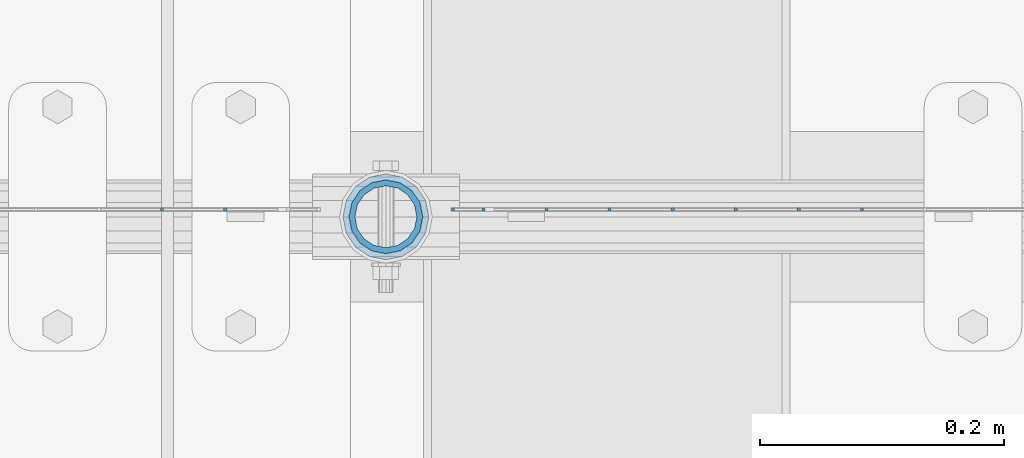
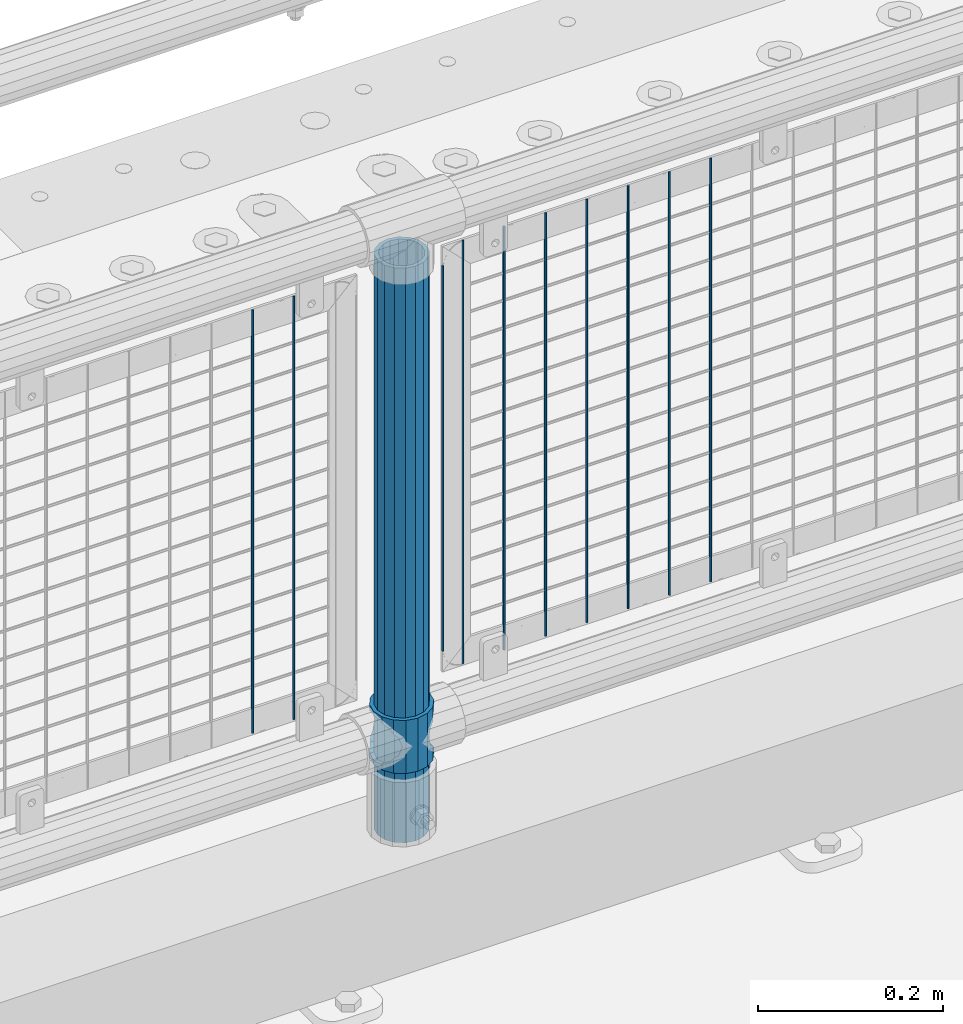
# One storey, part 90 of 240: 12 columns.
"""IFC2X3 building model written with IfcOpenShell, lengths in millimetres."""

from ifc_helpers import new_model, si_unit, frame, origin_with_axes, place, context, subcontext, project, spatial, faceted_brep, material, type_object, element, save


model = new_model("IFC2X3")

# Units and contexts
model_context = context("Model", 3, precision=1e-05, world=origin_with_axes())
body_context = subcontext(model_context, "Body", "Model", "MODEL_VIEW")
ifc_project = project(units=[si_unit("LENGTHUNIT", "METRE", prefix="MILLI"), si_unit("AREAUNIT", "SQUARE_METRE"), si_unit("VOLUMEUNIT", "CUBIC_METRE"), si_unit("MASSUNIT", "GRAM", prefix="KILO"), si_unit("TIMEUNIT", "SECOND"), si_unit("PLANEANGLEUNIT", "RADIAN"), si_unit("SOLIDANGLEUNIT", "STERADIAN"), si_unit("THERMODYNAMICTEMPERATUREUNIT", "DEGREE_CELSIUS"), si_unit("LUMINOUSINTENSITYUNIT", "LUMEN")], contexts=[model_context])

# Site, building, storey
site_placement = place(None, origin_with_axes())
site = spatial("IfcSite", under=ifc_project, at=site_placement, CompositionType="ELEMENT")
building_placement = place(site_placement, origin_with_axes())
building = spatial("IfcBuilding", under=site, at=building_placement, Name="Standard", CompositionType="ELEMENT")
storey_placement = place(building_placement, origin_with_axes())
storey = spatial("IfcBuildingStorey", under=building, at=storey_placement, Name="Undefined", CompositionType="ELEMENT", Elevation=0.0)

# Columns
ifc_material_1 = material(Name="Misc_Undefined")
column_type_1 = type_object("IfcColumnType", PredefinedType="NOTDEFINED")
column_1_placement = place(storey_placement, frame((53019.0, 34664.5, 263.02), z_axis=(-1.0, 0.0, 0.0), x_axis=(0.0, 0.0, 1.0)))
element("IfcColumn", 1, at=column_1_placement, inside=storey, type_object=column_type_1, material=ifc_material_1, context=body_context, shape_type="Brep", body=[
    faceted_brep([(56.6106908090114, 21.4606908090136, -21.4606908090136), (56.6106908090114, 21.4606908090136, -27.1226768591077), (61.9623795176703, 13.4513226476338, -32.4743655677739), (63.1897438117172, 11.6144421722784, -32.8397438117172), (63.1897438117172, 11.6144421722784, -28.0397438117143), (46.7644421722801, 28.0397438117143, -11.6144421722784), (46.7644421722801, 28.0397438117143, -20.0882031229849), (51.5310424079941, 24.8548033587067, -24.8548033587067), (35.1500000000015, 30.35, 0.0), (35.1499999999996, 30.3499999999985, -16.6306603983685), (23.5355578277192, 28.0397438117143, -11.6144421722784), (23.5355578277192, 28.0397438117143, -20.0882031229849), (13.6893091909879, 21.4606908090136, -21.4606908090136), (13.6893091909879, 21.4606908090136, -27.1226768591077), (18.7689575919921, 24.8548033587067, -24.8548033587067), (7.11025618828211, 11.6144421722784, -28.0397438117143), (7.11025618828211, 11.6144421722784, -32.8397438117172), (8.33762048232893, 13.4513226476338, -32.4743655677739), (4.79999999999961, 0.0, -30.3499999999985), (4.79999999999961, 0.0, -35.1500000000015), (7.11025618828211, -11.6144421722784, -28.0397438117143), (7.11025618828211, -11.6144421722784, -32.8397438117245), (13.6893091909879, -21.4606908090136, -21.4606908090136), (13.6893091909879, -21.4606908090136, -27.1226768591223), (8.33762048232455, -13.4513226476338, -32.4743655677739), (23.5355578277191, -28.0397438117143, -11.6144421722784), (23.5355578277191, -28.0397438117143, -20.0882031229994), (18.7689575919987, -24.8548033587067, -24.8548033587067), (35.1500000000015, -30.35, 0.0), (35.1499999999996, -30.3499999999985, -16.6306603983758), (46.7644421722801, -28.0397438117143, -11.6144421722784), (46.7644421722801, -28.0397438117143, -20.0882031229994), (56.6106908090114, -21.4606908090136, -21.4606908090136), (56.6106908090114, -21.4606908090136, -27.1226768591223), (51.5310424080006, -24.8548033587067, -24.8548033587067), (63.1897438117172, -11.6144421722784, -28.0397438117143), (63.1897438117172, -11.6144421722784, -32.8397438117245), (61.9623795176703, -13.4513226476338, -32.4743655677739), (65.4999999999997, 0.0, -30.3499999999985), (65.4999999999997, 0.0, -35.1500000000015), (0.0, -28.0397438117143, -11.6144421722784), (0.0, -30.3499999999985, 0.0), (0.0, -21.4606908090136, -21.4606908090136), (0.0, -11.6144421722784, -28.0397438117143), (0.0, 0.0, -30.3499999999985), (0.0, 11.6144421722784, -28.0397438117143), (0.0, 21.4606908090136, -21.4606908090136), (0.0, 28.0397438117143, -11.6144421722784), (0.0, 30.3499999999985, 0.0), (0.0, 28.0397438117143, 11.6144421722784), (23.5355578277192, 28.0397438117143, 11.6144421722784), (0.0, 21.4606908090136, 21.4606908090136), (13.6893091909879, 21.4606908090136, 21.4606908090136), (0.0, 11.6144421722784, 28.0397438117143), (7.11025618828211, 11.6144421722784, 28.0397438117143), (0.0, 0.0, 30.3499999999985), (4.79999999999961, 0.0, 30.3499999999985), (0.0, -11.6144421722784, 28.0397438117143), (7.11025618828205, -11.6144421722784, 28.0397438117143), (0.0, -21.4606908090136, 21.4606908090136), (13.6893091909879, -21.4606908090136, 21.4606908090136), (0.0, -28.0397438117143, 11.6144421722784), (23.5355578277191, -28.0397438117143, 11.6144421722784), (0.0, -32.4743655677739, 13.4513226476338), (0.0, -35.1500000000015, 0.0), (70.2999999999993, -35.1500000000015, 0.0), (70.2999999999993, -32.4743655677739, 13.4513226476338), (0.0, 13.4513226476338, -32.4743655677739), (0.0, 24.8548033587067, -24.8548033587067), (0.0, 0.0, -35.1500000000015), (0.0, -13.4513226476338, -32.4743655677739), (0.0, -24.8548033587067, -24.8548033587067), (0.0, -24.8548033587067, 24.8548033587067), (0.0, -13.4513226476338, 32.4743655677739), (0.0, 0.0, 35.1500000000015), (0.0, 13.4513226476338, 32.4743655677739), (0.0, 24.8548033587067, 24.8548033587067), (0.0, 32.4743655677739, 13.4513226476338), (0.0, 35.1500000000015, 0.0), (0.0, 32.4743655677739, -13.4513226476338), (0.0, -32.4743655677739, -13.4513226476338), (70.2999999999993, 32.4743655677739, 13.4513226476338), (70.2999999999993, 35.1500000000015, 0.0), (70.2999999999993, 32.4743655677739, -13.4513226476338), (70.2999999999993, 24.8548033587067, -24.8548033587067), (70.2999999999993, 13.4513226476338, -32.4743655677739), (70.2999999999993, 0.0, -35.1500000000015), (70.2999999999993, -13.4513226476338, -32.4743655677739), (70.2999999999993, -24.8548033587067, -24.8548033587067), (70.2999999999993, -32.4743655677739, -13.4513226476338), (70.2999999999993, 28.0397438117143, 11.6144421722784), (70.2999999999993, 21.4606908090136, 21.4606908090136), (56.6106908090114, 21.4606908090136, 21.4606908090136), (46.7644421722801, 28.0397438117143, 11.6144421722784), (70.2999999999993, 11.6144421722784, 28.0397438117143), (63.1897438117172, 11.6144421722784, 28.0397438117143), (70.2999999999993, 0.0, 30.3499999999985), (65.4999999999997, 0.0, 30.3499999999985), (70.2999999999993, -11.6144421722784, 28.0397438117143), (63.1897438117172, -11.6144421722784, 28.0397438117143), (70.2999999999993, -21.4606908090136, 21.4606908090136), (56.6106908090114, -21.4606908090136, 21.4606908090136), (70.2999999999993, -28.0397438117143, 11.6144421722784), (46.7644421722801, -28.0397438117143, 11.6144421722784), (70.2999999999993, -11.6144421722784, -28.0397438117143), (70.2999999999993, 0.0, -30.3499999999985), (70.2999999999993, -21.4606908090136, -21.4606908090136), (70.2999999999993, -28.0397438117143, -11.6144421722784), (70.2999999999993, -30.3499999999985, 0.0), (70.2999999999993, 24.8548033587067, 24.8548033587067), (70.2999999999993, 13.4513226476338, 32.4743655677739), (70.2999999999993, 0.0, 35.1500000000015), (70.2999999999993, -13.4513226476338, 32.4743655677739), (70.2999999999993, -24.8548033587067, 24.8548033587067), (70.2999999999993, 30.3499999999985, 0.0), (70.2999999999993, 28.0397438117143, -11.6144421722784), (70.2999999999993, 21.4606908090136, -21.4606908090136), (70.2999999999993, 11.6144421722784, -28.0397438117143), (61.9623795176742, 13.4513226476338, 32.4743655677739), (51.5310424079941, 24.8548033587067, 24.8548033587067), (56.6106908090114, 21.4606908090136, 27.1226768591077), (65.4999999999997, 0.0, 35.1500000000015), (63.1897438117172, 11.6144421722784, 32.8397438117172), (63.1897438117172, -11.6144421722784, 32.8397438117172), (61.9623795176698, -13.4513226476338, 32.4743655677739), (56.6106908090114, -21.4606908090136, 27.1226768591005), (51.5310424080006, -24.8548033587067, 24.8548033587067), (18.7689575919987, -24.8548033587067, 24.8548033587067), (46.7644421722801, -28.0397438117143, 20.0882031229994), (35.1499999999996, -30.3499999999985, 16.6306603983758), (23.5355578277191, -28.0397438117143, 20.0882031229994), (8.33762048232506, -13.4513226476338, 32.4743655677739), (13.6893091909879, -21.4606908090136, 27.1226768591005), (4.79999999999961, 0.0, 35.1500000000015), (7.11025618828205, -11.6144421722784, 32.8397438117172), (7.11025618828211, 11.6144421722784, 32.8397438117172), (8.33762048232506, 13.4513226476338, 32.4743655677739), (13.6893091909879, 21.4606908090136, 27.1226768591077), (18.7689575919856, 24.8548033587067, 24.8548033587067), (23.5355578277192, 28.0397438117143, 20.0882031229994), (35.1499999999996, 30.3499999999985, 16.6306603983758), (46.7644421722801, 28.0397438117143, 20.0882031229994)], [[[0, 1, 2, 3, 4]], [[5, 6, 7, 1, 0]], [[8, 9, 6, 5]], [[10, 11, 9, 8]], [[12, 13, 14, 11, 10]], [[15, 16, 17, 13, 12]], [[18, 19, 16, 15]], [[20, 21, 19, 18]], [[22, 23, 24, 21, 20]], [[25, 26, 27, 23, 22]], [[28, 29, 26, 25]], [[30, 31, 29, 28]], [[32, 33, 34, 31, 30]], [[35, 36, 37, 33, 32]], [[38, 39, 36, 35]], [[4, 3, 39, 38]], [[40, 41, 28, 25]], [[42, 40, 25, 22]], [[43, 42, 22, 20]], [[44, 43, 20, 18]], [[45, 44, 18, 15]], [[46, 45, 15, 12]], [[47, 46, 12, 10]], [[48, 47, 10, 8]], [[49, 48, 8, 50]], [[51, 49, 50, 52]], [[53, 51, 52, 54]], [[55, 53, 54, 56]], [[57, 55, 56, 58]], [[59, 57, 58, 60]], [[61, 59, 60, 62]], [[41, 61, 62, 28]], [[63, 64, 65, 66]], [[17, 67, 68, 14, 13]], [[19, 69, 67, 17, 16]], [[70, 69, 19, 21, 24]], [[71, 70, 24, 23, 27]], [[63, 72, 73, 74, 75, 76, 77, 78, 79, 68, 67, 69, 70, 71, 80, 64], [40, 42, 43, 44, 45, 46, 47, 48, 49, 51, 53, 55, 57, 59, 61, 41]], [[78, 77, 81, 82]], [[79, 78, 82, 83]], [[14, 68, 79, 83, 84, 7, 6, 9, 11]], [[84, 85, 2, 1, 7]], [[85, 86, 39, 3, 2]], [[37, 87, 88, 34, 33]], [[39, 86, 87, 37, 36]], [[34, 88, 89, 80, 71, 27, 26, 29, 31]], [[64, 80, 89, 65]], [[90, 91, 92, 93]], [[91, 94, 95, 92]], [[94, 96, 97, 95]], [[96, 98, 99, 97]], [[98, 100, 101, 99]], [[100, 102, 103, 101]], [[104, 105, 38, 35]], [[106, 104, 35, 32]], [[107, 106, 32, 30]], [[108, 107, 30, 28]], [[102, 108, 28, 103]], [[88, 87, 86, 85, 84, 83, 82, 81, 109, 110, 111, 112, 113, 66, 65, 89], [100, 98, 96, 94, 91, 90, 114, 115, 116, 117, 105, 104, 106, 107, 108, 102]], [[118, 110, 109, 119, 120]], [[121, 111, 110, 118, 122]], [[112, 111, 121, 123, 124]], [[113, 112, 124, 125, 126]], [[127, 72, 63, 66, 113, 126, 128, 129, 130]], [[131, 73, 72, 127, 132]], [[133, 74, 73, 131, 134]], [[75, 74, 133, 135, 136]], [[76, 75, 136, 137, 138]], [[119, 109, 81, 77, 76, 138, 139, 140, 141]], [[92, 120, 119, 141, 93]], [[95, 122, 118, 120, 92]], [[97, 121, 122, 95]], [[99, 123, 121, 97]], [[101, 125, 124, 123, 99]], [[103, 128, 126, 125, 101]], [[28, 129, 128, 103]], [[62, 130, 129, 28]], [[60, 132, 127, 130, 62]], [[58, 134, 131, 132, 60]], [[56, 133, 134, 58]], [[54, 135, 133, 56]], [[52, 137, 136, 135, 54]], [[50, 139, 138, 137, 52]], [[8, 140, 139, 50]], [[93, 141, 140, 8]], [[114, 90, 93, 8]], [[115, 114, 8, 5]], [[116, 115, 5, 0]], [[117, 116, 0, 4]], [[105, 117, 4, 38]]]),
])
ifc_material_2 = material()
column_type_2 = type_object("IfcColumnType", PredefinedType="NOTDEFINED")
column_2_placement = place(storey_placement, frame((53019.0, 34664.5, 168.02), z_axis=(-1.0, 0.0, 0.0), x_axis=(0.0, 0.0, 1.0)))
element("IfcColumn", 2, at=column_2_placement, inside=storey, type_object=column_type_2, material=ifc_material_2, context=body_context, shape_type="Brep", body=[
    faceted_brep([(0.0, -25.3499999999985, 0.0), (0.0, -23.4203461491634, 9.70102501045767), (760.0, -23.4203461491634, 9.70102501045767), (760.0, -25.3499999999985, 0.0), (0.0, -17.9251569030821, 17.9251569030821), (760.0, -17.9251569030821, 17.9251569030821), (0.0, -9.70102501045767, 23.4203461491634), (760.0, -9.70102501045767, 23.4203461491634), (0.0, 0.0, 25.3499999999985), (760.0, 0.0, 25.3499999999985), (0.0, 9.70102501045767, 23.4203461491634), (760.0, 9.70102501045767, 23.4203461491634), (0.0, 17.9251569030821, 17.9251569030821), (760.0, 17.9251569030821, 17.9251569030821), (0.0, 23.4203461491634, 9.70102501045767), (760.0, 23.4203461491634, 9.70102501045767), (0.0, 25.3499999999985, 0.0), (760.0, 25.3499999999985, 0.0), (0.0, 23.4203461491634, -9.70102501045767), (760.0, 23.4203461491634, -9.70102501045767), (0.0, 17.9251569030821, -17.9251569030821), (760.0, 17.9251569030821, -17.9251569030821), (0.0, 9.70102501045767, -23.4203461491634), (760.0, 9.70102501045767, -23.4203461491634), (0.0, 0.0, -25.3499999999985), (760.0, 0.0, -25.3499999999985), (0.0, -9.70102501045767, -23.4203461491634), (760.0, -9.70102501045767, -23.4203461491634), (0.0, -17.9251569030821, -17.9251569030821), (760.0, -17.9251569030821, -17.9251569030821), (0.0, -23.4203461491634, -9.70102501045767), (760.0, -23.4203461491634, -9.70102501045767), (0.0, -30.1500000000015, 0.0), (0.0, -27.8549679052157, -11.5379054858058), (760.0, -27.8549679052157, -11.5379054858058), (760.0, -30.1500000000015, 0.0), (0.0, -21.3192694527752, -21.3192694527752), (760.0, -21.3192694527752, -21.3192694527752), (0.0, -11.5379054858058, -27.8549679052157), (760.0, -11.5379054858058, -27.8549679052157), (0.0, 0.0, -30.1500000000015), (760.0, 0.0, -30.1500000000015), (0.0, 11.5379054858058, -27.8549679052157), (760.0, 11.5379054858058, -27.8549679052157), (0.0, 21.3192694527752, -21.3192694527752), (760.0, 21.3192694527752, -21.3192694527752), (0.0, 27.8549679052157, -11.5379054858058), (760.0, 27.8549679052157, -11.5379054858058), (0.0, 30.1500000000015, 0.0), (760.0, 30.1500000000015, 0.0), (0.0, 27.8549679052157, 11.5379054858058), (760.0, 27.8549679052157, 11.5379054858058), (0.0, 21.3192694527752, 21.3192694527752), (760.0, 21.3192694527752, 21.3192694527752), (0.0, 11.5379054858058, 27.8549679052157), (760.0, 11.5379054858058, 27.8549679052157), (0.0, 0.0, 30.1500000000015), (760.0, 0.0, 30.1500000000015), (0.0, -11.5379054858058, 27.8549679052157), (760.0, -11.5379054858058, 27.8549679052157), (0.0, -21.3192694527752, 21.3192694527752), (760.0, -21.3192694527752, 21.3192694527752), (0.0, -27.8549679052157, 11.5379054858058), (760.0, -27.8549679052157, 11.5379054858058)], [[[0, 1, 2, 3]], [[1, 4, 5, 2]], [[4, 6, 7, 5]], [[6, 8, 9, 7]], [[8, 10, 11, 9]], [[10, 12, 13, 11]], [[12, 14, 15, 13]], [[14, 16, 17, 15]], [[16, 18, 19, 17]], [[18, 20, 21, 19]], [[20, 22, 23, 21]], [[22, 24, 25, 23]], [[24, 26, 27, 25]], [[26, 28, 29, 27]], [[28, 30, 31, 29]], [[30, 0, 3, 31]], [[32, 33, 34, 35]], [[33, 36, 37, 34]], [[36, 38, 39, 37]], [[38, 40, 41, 39]], [[40, 42, 43, 41]], [[42, 44, 45, 43]], [[44, 46, 47, 45]], [[46, 48, 49, 47]], [[48, 50, 51, 49]], [[50, 52, 53, 51]], [[52, 54, 55, 53]], [[54, 56, 57, 55]], [[56, 58, 59, 57]], [[58, 60, 61, 59]], [[60, 62, 63, 61]], [[62, 32, 35, 63]], [[37, 39, 41, 43, 45, 47, 49, 51, 53, 55, 57, 59, 61, 63, 35, 34], [5, 7, 9, 11, 13, 15, 17, 19, 21, 23, 25, 27, 29, 31, 3, 2]], [[62, 60, 58, 56, 54, 52, 50, 48, 46, 44, 42, 40, 38, 36, 33, 32], [30, 28, 26, 24, 22, 20, 18, 16, 14, 12, 10, 8, 6, 4, 1, 0]]]),
])
column_type_3 = type_object("IfcColumnType", Name="D3", PredefinedType="NOTDEFINED")
for number, where, z_axis, x_axis in (
    (3, (53408.93, 34670.5, 353.020000000001), (-1.0, 0.0, 0.0), (0.0, 0.0, 1.0)),
    (4, (53357.275, 34670.5, 353.020000000001), (-1.0, 0.0, 0.0), (0.0, 0.0, 1.0)),
    (5, (53305.62, 34670.5, 353.020000000001), (-1.0, 0.0, 0.0), (0.0, 0.0, 1.0)),
    (6, (53253.965, 34670.5, 353.020000000001), (-1.0, 0.0, 0.0), (0.0, 0.0, 1.0)),
    (7, (53202.31, 34670.5, 353.020000000001), (-1.0, 0.0, 0.0), (0.0, 0.0, 1.0)),
    (8, (53150.655, 34670.5, 353.020000000001), (-1.0, 0.0, 0.0), (0.0, 0.0, 1.0)),
):
    element("IfcColumn", number, at=place(storey_placement, frame(where, z_axis=z_axis, x_axis=x_axis)), inside=storey, type_object=column_type_3, material=ifc_material_1, ObjectType="D3", context=body_context, shape_type="Brep", body=[
        faceted_brep([(-7.27595761418343e-12, -1.49999999999272, 0.0), (-7.27595761418343e-12, -0.749999999992724, -1.29903810567669), (560.0, -0.75, -1.29903810567339), (560.0, -1.5, 0.0), (0.0, 0.750000000007276, -1.29903810567669), (560.0, 0.75, -1.29903810567339), (0.0, 1.50000000000728, 0.0), (560.0, 1.5, 0.0), (0.0, 0.750000000007276, 1.29903810567669), (560.0, 0.75, 1.29903810567339), (-7.27595761418343e-12, -0.749999999992724, 1.29903810567669), (560.0, -0.75, 1.29903810567339)], [[[0, 1, 2, 3]], [[1, 4, 5, 2]], [[4, 6, 7, 5]], [[6, 8, 9, 7]], [[8, 10, 11, 9]], [[10, 0, 3, 11]], [[5, 7, 9, 11, 3, 2]], [[10, 8, 6, 4, 1, 0]]]),
    ])
column_3_placement = place(storey_placement, frame((53074.0, 34670.5, 378.020000000001), z_axis=(-1.0, 0.0, 0.0), x_axis=(0.0, 0.0, 1.0)))
element("IfcColumn", 9, at=column_3_placement, inside=storey, type_object=column_type_3, material=ifc_material_1, ObjectType="D3", context=body_context, shape_type="Brep", body=[
    faceted_brep([(-7.27595761418343e-12, -1.49999999999272, 0.0), (-7.27595761418343e-12, -0.749999999992724, -1.29903810567669), (510.0, -0.75, -1.29903810567339), (510.0, -1.5, 0.0), (0.0, 0.750000000007276, -1.29903810567669), (510.0, 0.75, -1.29903810567339), (0.0, 1.50000000000728, 0.0), (510.0, 1.5, 0.0), (0.0, 0.750000000007276, 1.29903810567669), (510.0, 0.75, 1.29903810567339), (-7.27595761418343e-12, -0.749999999992724, 1.29903810567669), (510.0, -0.75, 1.29903810567339)], [[[0, 1, 2, 3]], [[1, 4, 5, 2]], [[4, 6, 7, 5]], [[6, 8, 9, 7]], [[8, 10, 11, 9]], [[10, 0, 3, 11]], [[5, 7, 9, 11, 3, 2]], [[10, 8, 6, 4, 1, 0]]]),
])
for number, where, z_axis, x_axis in (
    (10, (53099.0, 34670.5, 353.020000000001), (-1.0, 0.0, 0.0), (0.0, 0.0, 1.0)),
    (11, (52887.34, 34670.5, 353.020000000001), (-1.0, 0.0, 0.0), (0.0, 0.0, 1.0)),
    (12, (52835.685, 34670.5, 353.020000000001), (-1.0, 0.0, 0.0), (0.0, 0.0, 1.0)),
):
    element("IfcColumn", number, at=place(storey_placement, frame(where, z_axis=z_axis, x_axis=x_axis)), inside=storey, type_object=column_type_3, material=ifc_material_1, ObjectType="D3", context=body_context, shape_type="Brep", body=[
        faceted_brep([(-7.27595761418343e-12, -1.49999999999272, 0.0), (-7.27595761418343e-12, -0.749999999992724, -1.29903810567669), (560.0, -0.75, -1.29903810567339), (560.0, -1.5, 0.0), (0.0, 0.750000000007276, -1.29903810567669), (560.0, 0.75, -1.29903810567339), (0.0, 1.50000000000728, 0.0), (560.0, 1.5, 0.0), (0.0, 0.750000000007276, 1.29903810567669), (560.0, 0.75, 1.29903810567339), (-7.27595761418343e-12, -0.749999999992724, 1.29903810567669), (560.0, -0.75, 1.29903810567339)], [[[0, 1, 2, 3]], [[1, 4, 5, 2]], [[4, 6, 7, 5]], [[6, 8, 9, 7]], [[8, 10, 11, 9]], [[10, 0, 3, 11]], [[5, 7, 9, 11, 3, 2]], [[10, 8, 6, 4, 1, 0]]]),
    ])

save(model, "model.ifc")
